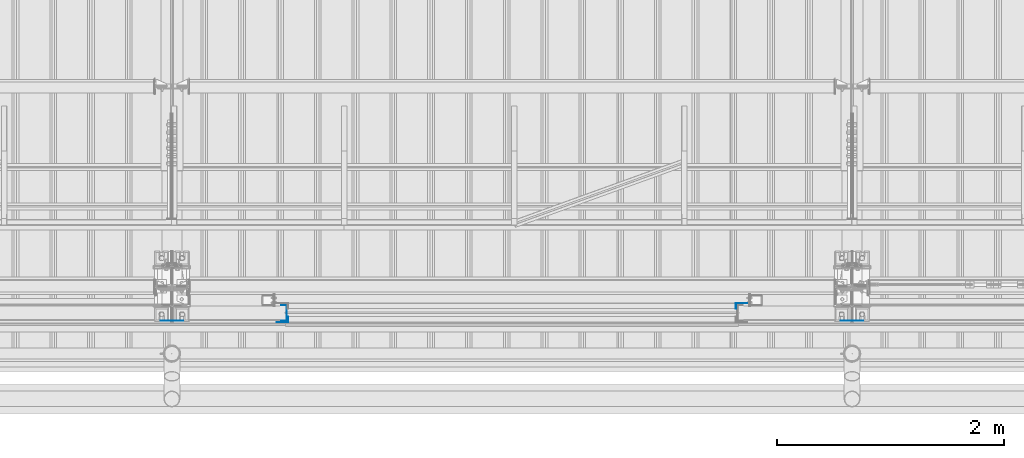
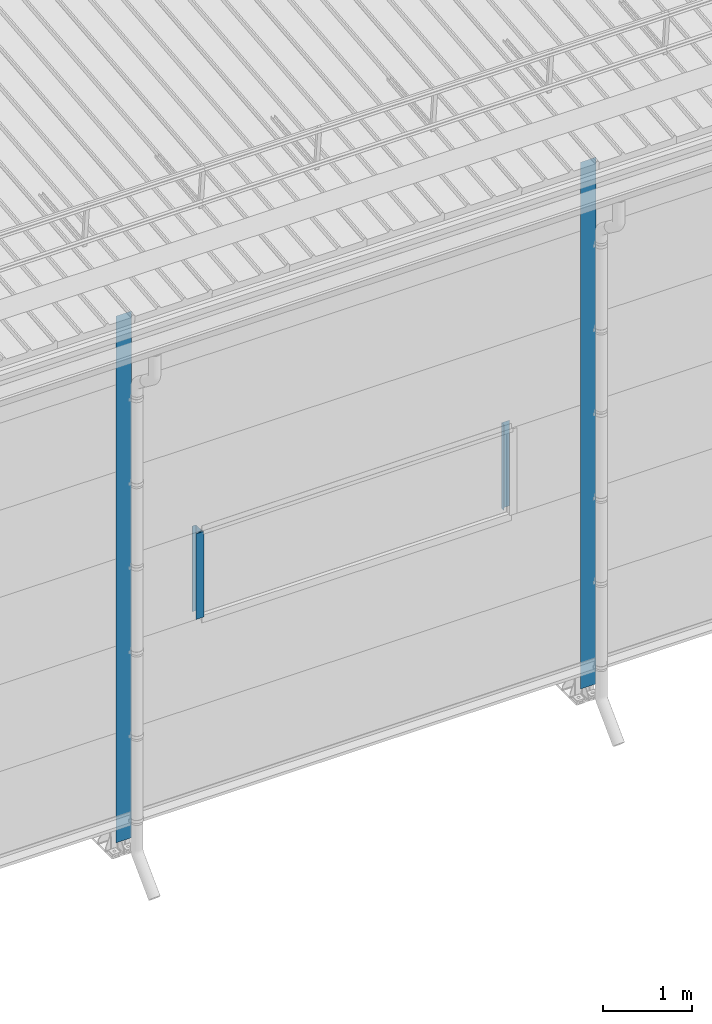
# One storey, part 5 of 709: 5 columns, 5 elements without a shape of their own.
"""IFC4 building model written with IfcOpenShell, lengths in millimetres."""

from ifc_helpers import new_model, si_unit, direction, frame, origin_with_axes, place, context, subcontext, project, spatial, line, indexed_curve, outline, extrude, material, element, aggregate, save


model = new_model("IFC4")

# Units and contexts
model_context = context("Model", 3, precision=0.2, world=origin_with_axes(), true_north=direction((0.0, 1.0)))
body_context = subcontext(model_context, "Body", "Model", "MODEL_VIEW")
ifc_project = project(units=[si_unit("LENGTHUNIT", "METRE", prefix="MILLI"), si_unit("AREAUNIT", "SQUARE_METRE"), si_unit("VOLUMEUNIT", "CUBIC_METRE"), si_unit("MASSUNIT", "GRAM", prefix="KILO"), si_unit("TIMEUNIT", "SECOND"), si_unit("PLANEANGLEUNIT", "RADIAN"), si_unit("SOLIDANGLEUNIT", "STERADIAN"), si_unit("THERMODYNAMICTEMPERATUREUNIT", "DEGREE_CELSIUS"), si_unit("LUMINOUSINTENSITYUNIT", "LUMEN")], contexts=[model_context])

# Site, building, storey
site_placement = place(None, origin_with_axes())
site = spatial("IfcSite", under=ifc_project, at=site_placement, CompositionType="ELEMENT")
building_placement = place(site_placement, origin_with_axes())
building = spatial("IfcBuilding", under=site, at=building_placement, Name="Undefined", CompositionType="ELEMENT")
storey_placement = place(building_placement, origin_with_axes())
storey = spatial("IfcBuildingStorey", under=building, at=storey_placement, Name="Undefined", CompositionType="ELEMENT", Elevation=0.0)

# Assembly, column
assembly_1_placement = place(storey_placement, frame((20975.0, 1.0, 2700.0), z_axis=(0.0, 1.0, 0.0), x_axis=(0.0, 0.0, 1.0)))
assembly_1 = element("IfcElementAssembly", 1, at=assembly_1_placement, inside=storey)
ifc_material = material(Name="Steel_Undefined", Category="STEEL")
column_1_placement = place(assembly_1_placement, origin_with_axes())
column_1 = element("IfcColumn", 2, at=column_1_placement, material=ifc_material, context=body_context, shape_type="SolidModel", body=[
    extrude(outline(indexed_curve([(-25.0, -1.0), (25.0, -1.0), (25.0, 99.0), (23.0, 99.0), (23.0, 1.0), (-25.0, 1.0)], segments=[line(1, 2, 3, 4, 5, 6, 1)])), frame((0.0, 0.0, 0.0), z_axis=(-1.0, 0.0, 0.0), x_axis=(0.0, 0.0, 1.0)), (0.0, 0.0, -1.0), 1170.0),
])
aggregate(assembly_1, [column_1])

assembly_2_placement = place(storey_placement, frame((16990.0, -60.0, 2700.0), z_axis=(0.0, 1.0, 0.0), x_axis=(0.0, 0.0, 1.0)))
assembly_2 = element("IfcElementAssembly", 3, at=assembly_2_placement, inside=storey)
column_2_placement = place(assembly_2_placement, origin_with_axes())
column_2 = element("IfcColumn", 4, at=column_2_placement, material=ifc_material, context=body_context, shape_type="SolidModel", body=[
    extrude(outline(indexed_curve([(-70.0, -25.0), (-68.0, -25.0), (-68.0, 23.0), (68.0, 23.0), (68.0, -25.0), (70.0, -25.0), (70.0, 25.0), (-70.0, 25.0)], segments=[line(1, 2, 3, 4, 5, 6, 7, 8, 1)])), frame((0.0, 0.0, 0.0), z_axis=(-1.0, 0.0, 0.0), x_axis=(0.0, 0.0, 1.0)), (0.0, 0.0, -1.0), 1170.0),
])
aggregate(assembly_2, [column_2])

assembly_3_placement = place(storey_placement, frame((17025.0, -119.0, 2700.0), z_axis=(0.0, -1.0, 0.0), x_axis=(0.0, 0.0, 1.0)))
assembly_3 = element("IfcElementAssembly", 5, at=assembly_3_placement, inside=storey)
column_3_placement = place(assembly_3_placement, origin_with_axes())
column_3 = element("IfcColumn", 6, at=column_3_placement, material=ifc_material, context=body_context, shape_type="SolidModel", body=[
    extrude(outline(indexed_curve([(-25.0, -1.0), (25.0, -1.0), (25.0, 99.0), (23.0, 99.0), (23.0, 1.0), (-25.0, 1.0)], segments=[line(1, 2, 3, 4, 5, 6, 1)])), frame((0.0, 0.0, 0.0), z_axis=(-1.0, 0.0, 0.0), x_axis=(0.0, 0.0, 1.0)), (0.0, 0.0, -1.0), 1170.0),
])
aggregate(assembly_3, [column_3])

assembly_4_placement = place(storey_placement, frame((16000.0, -130.0, 0.0), z_axis=(0.0, 1.0, 0.0), x_axis=(0.0, 0.0, 1.0)))
assembly_4 = element("IfcElementAssembly", 7, at=assembly_4_placement, inside=storey)
column_4_placement = place(assembly_4_placement, origin_with_axes())
column_4 = element("IfcColumn", 8, at=column_4_placement, material=ifc_material, context=body_context, shape_type="SolidModel", body=[
    extrude(outline(indexed_curve([(-0.375, -100.0), (1.245, -100.0), (1.245, -50.0), (0.495, -50.0), (0.495, -99.25), (0.375, -99.25), (0.375, 99.25), (0.495, 99.25), (0.495, 50.0), (1.245, 50.0), (1.245, 100.0), (-0.375, 100.0)], segments=[line(1, 2, 3, 4, 5, 6, 7, 8, 9, 10, 11, 12, 1)])), frame((0.0, 0.0, 0.0), z_axis=(-1.0, 0.0, 0.0), x_axis=(0.0, 0.0, 1.0)), (0.0, 0.0, -1.0), 7196.92297),
])
aggregate(assembly_4, [column_4])

assembly_5_placement = place(storey_placement, frame((22000.0, -130.0, 0.0), z_axis=(0.0, 1.0, 0.0), x_axis=(0.0, 0.0, 1.0)))
assembly_5 = element("IfcElementAssembly", 9, at=assembly_5_placement, inside=storey)
column_5_placement = place(assembly_5_placement, origin_with_axes())
column_5 = element("IfcColumn", 10, at=column_5_placement, material=ifc_material, context=body_context, shape_type="SolidModel", body=[
    extrude(outline(indexed_curve([(-0.375, -100.0), (1.245, -100.0), (1.245, -50.0), (0.495, -50.0), (0.495, -99.25), (0.375, -99.25), (0.375, 99.25), (0.495, 99.25), (0.495, 50.0), (1.245, 50.0), (1.245, 100.0), (-0.375, 100.0)], segments=[line(1, 2, 3, 4, 5, 6, 7, 8, 9, 10, 11, 12, 1)])), frame((0.0, 0.0, 0.0), z_axis=(-1.0, 0.0, 0.0), x_axis=(0.0, 0.0, 1.0)), (0.0, 0.0, -1.0), 7196.92297),
])
aggregate(assembly_5, [column_5])

save(model, "model.ifc")
